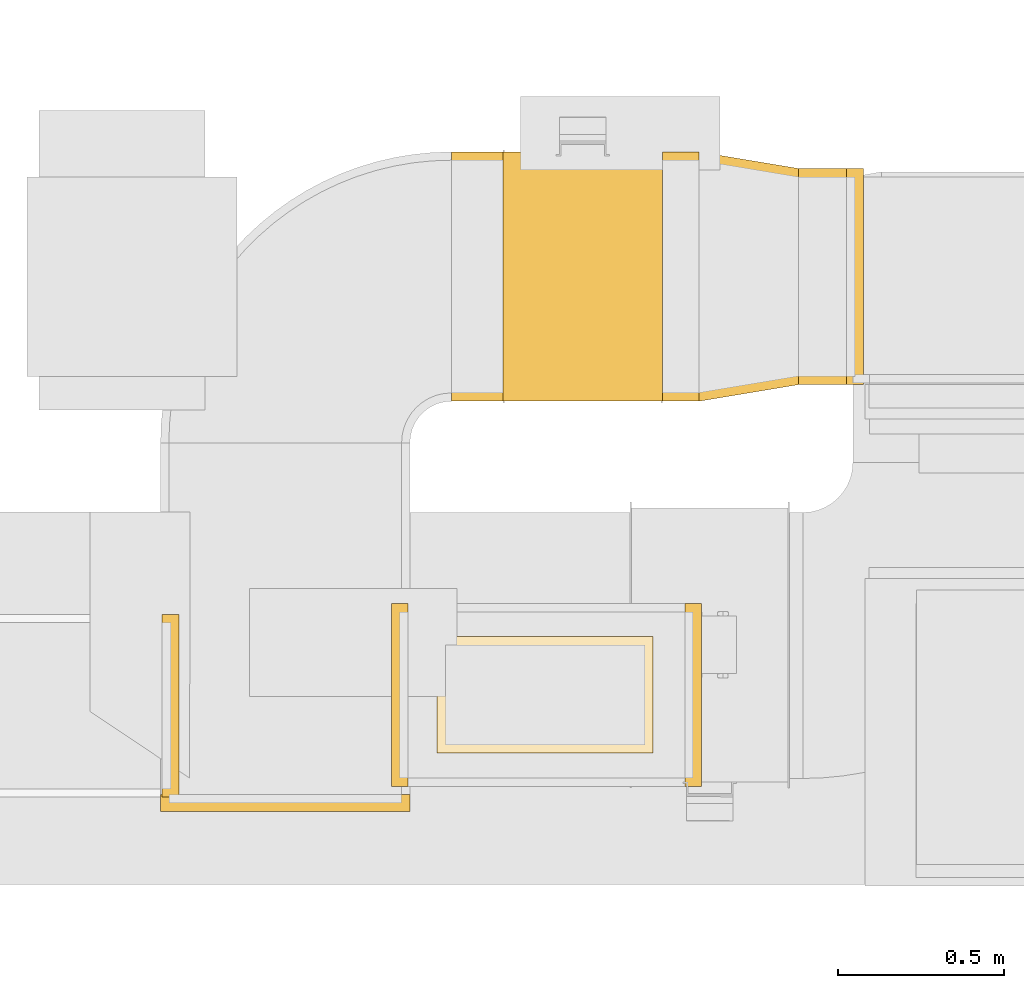
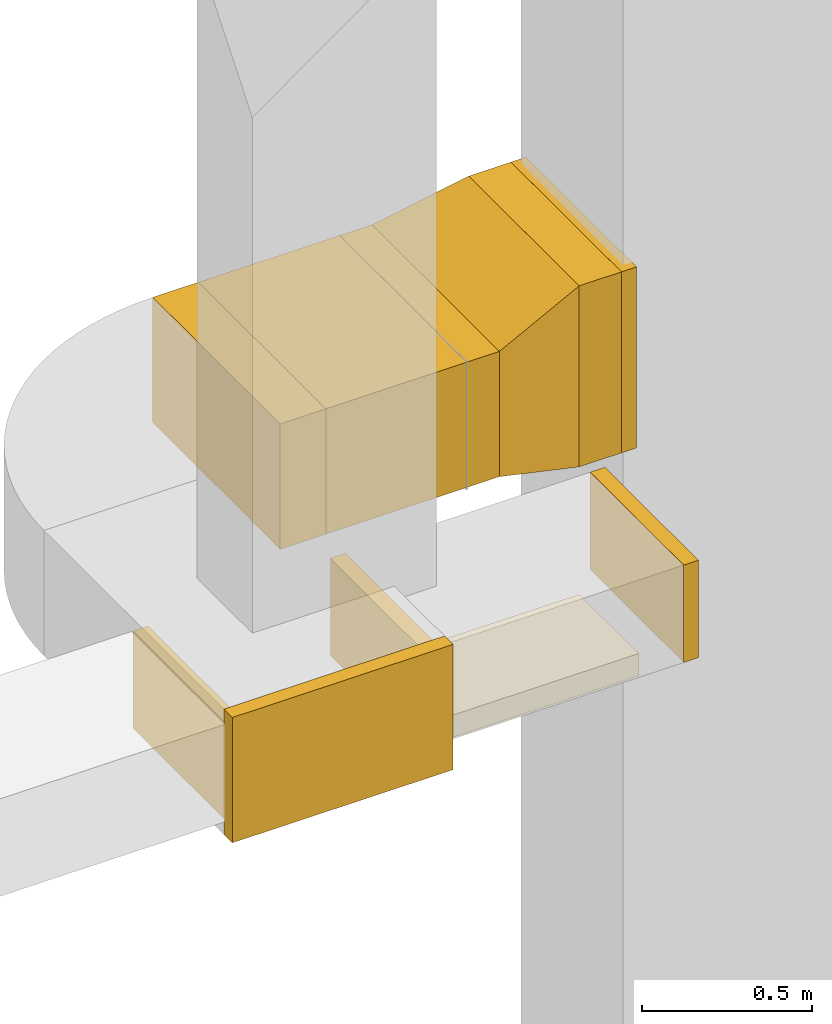
# One storey, part 4 of 29: 11 coverings.
"""IFC2X3 building model written with IfcOpenShell, lengths in millimetres."""

from ifc_helpers import new_model, entity, si_unit, converted_unit, derived_unit, direction, frame, frame_2d, origin, origin_2d_with_axis, place, context, subcontext, project, spatial, rectangle, extrude, faceted_brep, element, save


model = new_model("IFC2X3")

# Units and contexts
model_context = context("Model", 3, precision=0.01, world=origin(), true_north=direction((6.12303176911189e-17, 1.0)))
body_context = subcontext(model_context, "Body", "Model", "MODEL_VIEW")
ifc_project = project(units=[si_unit("LENGTHUNIT", "METRE", prefix="MILLI"), si_unit("AREAUNIT", "SQUARE_METRE"), si_unit("VOLUMEUNIT", "CUBIC_METRE"), converted_unit("PLANEANGLEUNIT", "DEGREE", entity("IfcRatioMeasure", 0.0174532925199433), si_unit("PLANEANGLEUNIT", "RADIAN"), dimensions=[0, 0, 0, 0, 0, 0, 0]), si_unit("MASSUNIT", "GRAM", prefix="KILO"), derived_unit("MASSDENSITYUNIT", [(si_unit("MASSUNIT", "GRAM", prefix="KILO"), 1), (si_unit("LENGTHUNIT", "METRE"), -3)]), derived_unit("MOMENTOFINERTIAUNIT", [(si_unit("LENGTHUNIT", "METRE"), 4)]), si_unit("TIMEUNIT", "SECOND"), si_unit("FREQUENCYUNIT", "HERTZ"), si_unit("THERMODYNAMICTEMPERATUREUNIT", "DEGREE_CELSIUS"), derived_unit("THERMALTRANSMITTANCEUNIT", [(si_unit("MASSUNIT", "GRAM", prefix="KILO"), 1), (si_unit("THERMODYNAMICTEMPERATUREUNIT", "KELVIN"), -1), (si_unit("TIMEUNIT", "SECOND"), -3)]), derived_unit("VOLUMETRICFLOWRATEUNIT", [(si_unit("LENGTHUNIT", "METRE"), 3), (si_unit("TIMEUNIT", "SECOND"), -1)]), derived_unit("MASSFLOWRATEUNIT", [(si_unit("MASSUNIT", "GRAM", prefix="KILO"), 1), (si_unit("TIMEUNIT", "SECOND"), -1)]), derived_unit("ROTATIONALFREQUENCYUNIT", [(si_unit("TIMEUNIT", "SECOND"), -1)]), si_unit("ELECTRICCURRENTUNIT", "AMPERE"), si_unit("ELECTRICVOLTAGEUNIT", "VOLT"), si_unit("POWERUNIT", "WATT"), si_unit("FORCEUNIT", "NEWTON", prefix="KILO"), si_unit("ILLUMINANCEUNIT", "LUX"), si_unit("LUMINOUSFLUXUNIT", "LUMEN"), si_unit("LUMINOUSINTENSITYUNIT", "CANDELA"), derived_unit("USERDEFINED", [(si_unit("MASSUNIT", "GRAM", prefix="KILO"), -1), (si_unit("LENGTHUNIT", "METRE"), -2), (si_unit("TIMEUNIT", "SECOND"), 3), (si_unit("LUMINOUSFLUXUNIT", "LUMEN"), 1)]), derived_unit("LINEARVELOCITYUNIT", [(si_unit("LENGTHUNIT", "METRE"), 1), (si_unit("TIMEUNIT", "SECOND"), -1)]), si_unit("PRESSUREUNIT", "PASCAL"), derived_unit("USERDEFINED", [(si_unit("LENGTHUNIT", "METRE"), -2), (si_unit("MASSUNIT", "GRAM", prefix="KILO"), 1), (si_unit("TIMEUNIT", "SECOND"), -2)]), derived_unit("LINEARFORCEUNIT", [(si_unit("MASSUNIT", "GRAM", prefix="KILO"), 1), (si_unit("LENGTHUNIT", "METRE"), 1), (si_unit("TIMEUNIT", "SECOND"), -2), (si_unit("LENGTHUNIT", "METRE"), -1)]), derived_unit("PLANARFORCEUNIT", [(si_unit("MASSUNIT", "GRAM", prefix="KILO"), 1), (si_unit("LENGTHUNIT", "METRE"), 1), (si_unit("TIMEUNIT", "SECOND"), -2), (si_unit("LENGTHUNIT", "METRE"), -2)])], contexts=[model_context])

# Site, building, storey
site_placement = place(None, frame((0.0, -0.00077364408347762, 0.0)))
site = spatial("IfcSite", under=ifc_project, at=site_placement, CompositionType="ELEMENT")
building_placement = place(site_placement, origin())
building = spatial("IfcBuilding", under=site, at=building_placement, CompositionType="ELEMENT")
storey_placement = place(building_placement, origin())
storey = spatial("IfcBuildingStorey", under=building, at=storey_placement, CompositionType="ELEMENT", Elevation=0.0)

# Coverings
covering_1_placement = place(storey_placement, frame((61964.2826729835, 9275.08023861377, 2475.0)))
element("IfcCovering", 1, at=covering_1_placement, inside=storey, PredefinedType="INSULATION", context=body_context, shape_type="SweptSolid", body=[
    extrude(rectangle(XDim=49.9999999999948, YDim=550.0, at=frame_2d((-4.33075797445781e-12, 1.62003743753303e-12), x_axis=(1.0, 0.0))), frame((25.0012509511801, 275.000113720014, 0.0), z_axis=(0.0, 0.0, 1.0), x_axis=(-1.0, 4.54891434412777e-06, 0.0)), (0.0, 0.0, 1.0), 349.999999999999),
])
covering_2_placement = place(storey_placement, frame((61081.4044629828, 9275.08046605657, 2475.0)))
element("IfcCovering", 2, at=covering_2_placement, inside=storey, PredefinedType="INSULATION", context=body_context, shape_type="SweptSolid", body=[
    extrude(rectangle(XDim=51.0960000000016, YDim=550.000000000001, at=origin_2d_with_axis()), frame((25.5480000000008, 275.0, 0.0), z_axis=(0.0, 0.0, 1.0), x_axis=(-1.0, 0.0, 0.0)), (0.0, 0.0, 1.0), 350.000000000001),
])
covering_3_placement = place(storey_placement, frame((60392.4877944138, 9242.34090440284, 2475.0)))
element("IfcCovering", 3, at=covering_3_placement, inside=storey, PredefinedType="INSULATION", context=body_context, shape_type="SweptSolid", body=[
    extrude(rectangle(XDim=550.000000000001, YDim=51.1213371379499, at=frame_2d((-5.40012479177676e-13, -4.33075797445781e-12), x_axis=(1.0, 0.0))), frame((25.5606685689879, 275.0, 0.0), z_axis=(0.0, 0.0, 1.0), x_axis=(0.0, -1.0, 0.0)), (0.0, 0.0, 1.0), 349.999999999999),
])
covering_4_placement = place(storey_placement, frame((62307.0867859532, 10483.5115060304, 2325.0)))
element("IfcCovering", 4, at=covering_4_placement, inside=storey, PredefinedType="INSULATION", context=body_context, shape_type="SweptSolid", body=[
    extrude(rectangle(XDim=143.50000000008, YDim=650.0, at=origin_2d_with_axis()), frame((71.75000000004, 325.0, 0.0), z_axis=(0.0, 0.0, 1.0), x_axis=(-1.0, 0.0, 0.0)), (0.0, 0.0, 1.0), 650.0),
])
covering_5_placement = place(storey_placement, frame((61417.4726519056, 10433.5115070617, 2425.0)))
element("IfcCovering", 5, at=covering_5_placement, inside=storey, PredefinedType="INSULATION", context=body_context, shape_type="SweptSolid", body=[
    extrude(rectangle(XDim=480.000000000008, YDim=750.000000000001, at=frame_2d((4.33431068813661e-12, 0.0), x_axis=(1.0, 0.0))), frame((240.027809564648, 375.017797512547, 0.0), z_axis=(0.0, 0.0, 1.0), x_axis=(0.999999997250103, 7.41605989871262e-05, 0.0)), (0.0, 0.0, 1.0), 450.0),
])
covering_6_placement = place(storey_placement, frame((60387.5004629828, 9200.08574557039, 2425.0)))
element("IfcCovering", 6, at=covering_6_placement, inside=storey, PredefinedType="INSULATION", context=body_context, shape_type="SweptSolid", body=[
    extrude(rectangle(XDim=50.0000000000016, YDim=750.000000000003, at=origin_2d_with_axis()), frame((375.0, 25.0, 0.0), z_axis=(0.0, 0.0, 1.0), x_axis=(0.0, 1.0, 0.0)), (0.0, 0.0, 1.0), 450.0),
])
covering_7_placement = place(storey_placement, frame((62450.5867859533, 10483.5115060304, 2325.0)))
element("IfcCovering", 7, at=covering_7_placement, inside=storey, PredefinedType="INSULATION", context=body_context, shape_type="SweptSolid", body=[
    extrude(rectangle(XDim=650.0, YDim=51.0960000000016, at=origin_2d_with_axis()), frame((25.5479999999921, 325.0, 0.0), z_axis=(0.0, 0.0, 1.0), x_axis=(0.0, -1.0, 0.0)), (0.0, 0.0, 1.0), 650.0),
])
covering_8_placement = place(storey_placement, frame((61897.5004608103, 10433.547103118, 2425.0)))
element("IfcCovering", 8, at=covering_8_placement, inside=storey, PredefinedType="INSULATION", context=body_context, shape_type="SweptSolid", body=[
    extrude(rectangle(XDim=109.586325142914, YDim=749.999999999998, at=origin_2d_with_axis()), frame((54.7931625715089, 375.0, 0.0)), (0.0, 0.0, 1.0), 450.0),
])
covering_9_placement = place(storey_placement, frame((62007.0867859532, 10433.5471031181, 2325.0)))
element("IfcCovering", 9, at=covering_9_placement, inside=storey, PredefinedType="INSULATION", context=body_context, shape_type="Brep", body=[
    faceted_brep([(300.0, 49.96440291236, 650.0), (300.0, 49.96440291236, 0.0), (300.0, 699.96440291236, 0.0), (300.0, 699.96440291236, 650.0), (0.0, 0.0, 550.0), (0.0, 750.0, 550.0), (0.0, 750.0, 100.0), (0.0, 0.0, 100.0)], [[[0, 1, 2, 3]], [[4, 5, 6, 7]], [[4, 7, 1, 0]], [[7, 6, 2, 1]], [[6, 5, 3, 2]], [[5, 4, 0, 3]]]),
])
covering_10_placement = place(storey_placement, frame((61262.4726527581, 10433.5000121689, 2425.0)))
element("IfcCovering", 10, at=covering_10_placement, inside=storey, PredefinedType="INSULATION", context=body_context, shape_type="SweptSolid", body=[
    extrude(rectangle(XDim=154.999999573749, YDim=750.000000000001, at=frame_2d((0.0, 1.08002495835535e-12), x_axis=(1.0, 0.0))), frame((77.5278097983852, 375.005746415195, 0.0), z_axis=(0.0, 0.0, 1.0), x_axis=(0.999999997250103, 7.41605989985116e-05, 0.0)), (0.0, 0.0, 1.0), 450.0),
])
covering_11_placement = place(storey_placement, frame((61219.3470649029, 9375.08046605664, 2400.0)))
element("IfcCovering", 11, at=covering_11_placement, inside=storey, PredefinedType="INSULATION", context=body_context, shape_type="SweptSolid", body=[
    extrude(rectangle(XDim=650.000000000008, YDim=350.000000000001, at=frame_2d((0.0, 1.08002495835535e-12), x_axis=(1.0, 0.0))), frame((325.0, 175.0, 0.0), z_axis=(0.0, 0.0, 1.0), x_axis=(-1.0, 0.0, 0.0)), (0.0, 0.0, 1.0), 79.999999999987),
])

save(model, "model.ifc")
